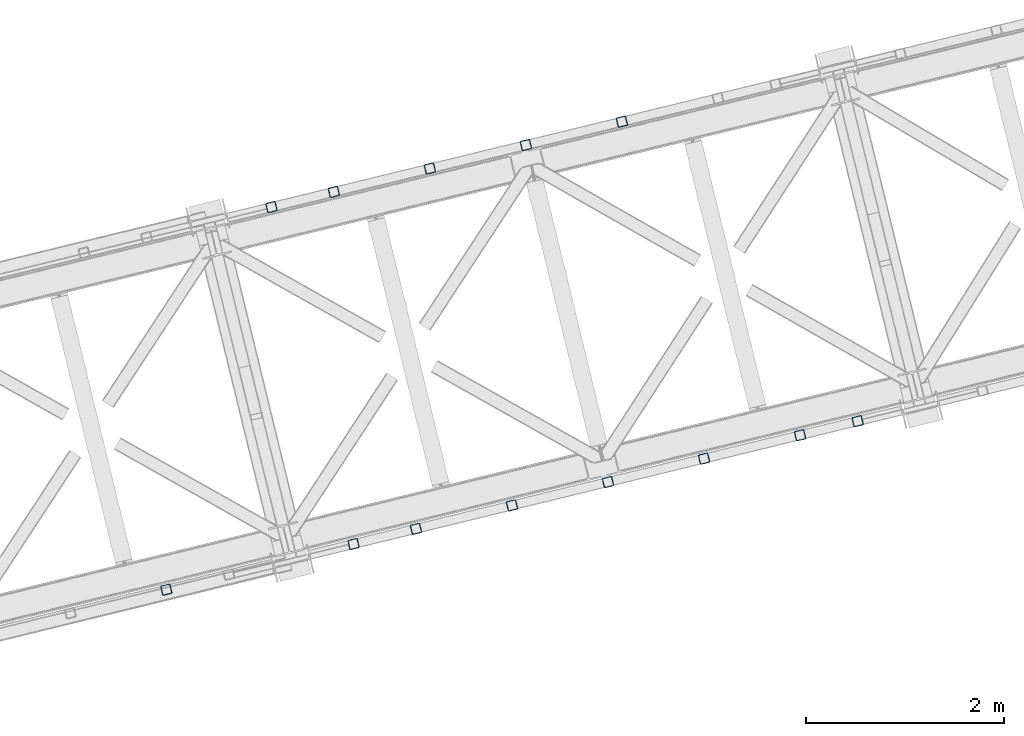
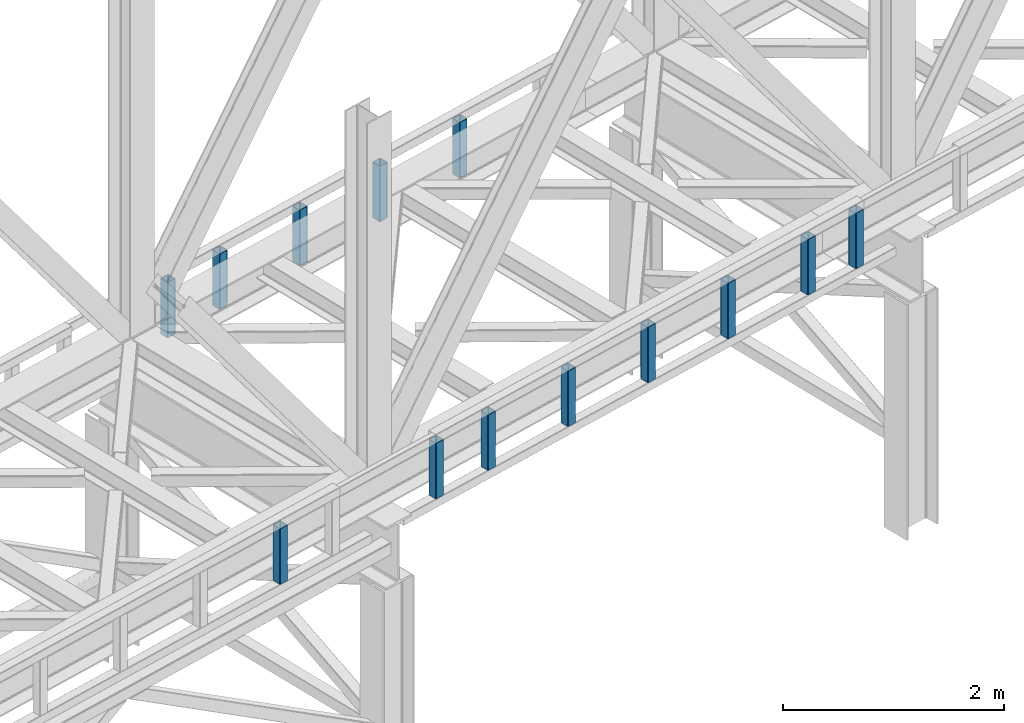
# One storey, part 8 of 93: 13 columns.
"""IFC4 building model written with IfcOpenShell, lengths in millimetres."""

from ifc_helpers import new_model, entity, si_unit, converted_unit, derived_unit, direction, frame, origin, place, context, subcontext, project, spatial, indexed_curve, outline, extrude, type_object, element, save


model = new_model("IFC4")

# Units and contexts
model_context = context("Model", 3, precision=0.01, world=origin(), true_north=direction((6.12303176911189e-17, 1.0)))
plan_context = context("Plan", 3, precision=0.01, world=origin(), true_north=direction((6.12303176911189e-17, 1.0)))
body_context = subcontext(model_context, "Body", "Model", "MODEL_VIEW")
ifc_project = project(units=[si_unit("LENGTHUNIT", "METRE", prefix="MILLI"), si_unit("AREAUNIT", "SQUARE_METRE"), si_unit("VOLUMEUNIT", "CUBIC_METRE"), converted_unit("PLANEANGLEUNIT", "DEGREE", entity("IfcRatioMeasure", 0.0174532925199433), si_unit("PLANEANGLEUNIT", "RADIAN"), dimensions=[0, 0, 0, 0, 0, 0, 0]), si_unit("MASSUNIT", "GRAM", prefix="KILO"), derived_unit("MASSDENSITYUNIT", [(si_unit("MASSUNIT", "GRAM", prefix="KILO"), 1), (si_unit("LENGTHUNIT", "METRE"), -3)]), derived_unit("MOMENTOFINERTIAUNIT", [(si_unit("LENGTHUNIT", "METRE"), 4)]), si_unit("TIMEUNIT", "SECOND"), si_unit("FREQUENCYUNIT", "HERTZ"), si_unit("THERMODYNAMICTEMPERATUREUNIT", "DEGREE_CELSIUS"), derived_unit("THERMALTRANSMITTANCEUNIT", [(si_unit("MASSUNIT", "GRAM", prefix="KILO"), 1), (si_unit("THERMODYNAMICTEMPERATUREUNIT", "KELVIN"), -1), (si_unit("TIMEUNIT", "SECOND"), -3)]), derived_unit("VOLUMETRICFLOWRATEUNIT", [(si_unit("LENGTHUNIT", "METRE"), 3), (si_unit("TIMEUNIT", "SECOND"), -1)]), derived_unit("MASSFLOWRATEUNIT", [(si_unit("MASSUNIT", "GRAM", prefix="KILO"), 1), (si_unit("TIMEUNIT", "SECOND"), -1)]), derived_unit("ROTATIONALFREQUENCYUNIT", [(si_unit("TIMEUNIT", "SECOND"), -1)]), si_unit("ELECTRICCURRENTUNIT", "AMPERE"), si_unit("ELECTRICVOLTAGEUNIT", "VOLT"), si_unit("POWERUNIT", "WATT"), si_unit("FORCEUNIT", "NEWTON", prefix="KILO"), si_unit("ILLUMINANCEUNIT", "LUX"), si_unit("LUMINOUSFLUXUNIT", "LUMEN"), si_unit("LUMINOUSINTENSITYUNIT", "CANDELA"), derived_unit("USERDEFINED", [(si_unit("MASSUNIT", "GRAM", prefix="KILO"), -1), (si_unit("LENGTHUNIT", "METRE"), -2), (si_unit("TIMEUNIT", "SECOND"), 3), (si_unit("LUMINOUSFLUXUNIT", "LUMEN"), 1)]), derived_unit("LINEARVELOCITYUNIT", [(si_unit("LENGTHUNIT", "METRE"), 1), (si_unit("TIMEUNIT", "SECOND"), -1)]), si_unit("PRESSUREUNIT", "PASCAL"), derived_unit("USERDEFINED", [(si_unit("LENGTHUNIT", "METRE"), -2), (si_unit("MASSUNIT", "GRAM", prefix="KILO"), 1), (si_unit("TIMEUNIT", "SECOND"), -2)]), derived_unit("LINEARFORCEUNIT", [(si_unit("MASSUNIT", "GRAM", prefix="KILO"), 1), (si_unit("LENGTHUNIT", "METRE"), 1), (si_unit("TIMEUNIT", "SECOND"), -2), (si_unit("LENGTHUNIT", "METRE"), -1)]), derived_unit("PLANARFORCEUNIT", [(si_unit("MASSUNIT", "GRAM", prefix="KILO"), 1), (si_unit("LENGTHUNIT", "METRE"), 1), (si_unit("TIMEUNIT", "SECOND"), -2), (si_unit("LENGTHUNIT", "METRE"), -2)])], contexts=[model_context, plan_context])

# Site, building, storey
site_placement = place(None, origin())
site = spatial("IfcSite", under=ifc_project, at=site_placement, CompositionType="ELEMENT")
building_placement = place(site_placement, origin())
building = spatial("IfcBuilding", under=site, at=building_placement, CompositionType="ELEMENT")
storey_placement = place(building_placement, frame((0.0, 0.0, 15900.0)))
storey = spatial("IfcBuildingStorey", under=building, at=storey_placement, CompositionType="ELEMENT", Elevation=15900.0)

# Columns
column_type_1 = type_object("IfcColumnType", PredefinedType="COLUMN")
column_1_placement = place(storey_placement, origin())
element("IfcColumn", 1, at=column_1_placement, inside=storey, type_object=column_type_1, ObjectType="Steel Column", PredefinedType="COLUMN", context=body_context, shape_type="SweptSolid", body=[
    extrude(outline(indexed_curve([(29.4768951153002, -56.8428769008257), (33.3787015556201, -56.8428769008257), (36.9835006656566, -55.3497202198225), (39.742494458495, -52.5907264269942), (41.2356511394973, -48.9859273169575), (56.8428769008221, 29.4768951152923), (56.8428769008298, 33.3787015556134), (55.349720219815, 36.9835006656505), (52.5907264269858, 39.7424944584821), (48.9859273169559, 41.2356511394885), (-29.476895115292, 56.8428769008124), (-33.3787015556159, 56.8428769008142), (-36.9835006656493, 55.3497202198072), (-39.7424944584781, 52.5907264269792), (-41.2356511394882, 48.9859273169462), (-56.8428769008091, -29.4768951153055), (-56.8428769008129, -33.3787015556285), (-55.3497202198068, -36.9835006656639), (-52.5907264269816, -39.7424944584937), (-48.9859273169477, -41.2356511395019), (29.4768951153002, -56.8428769008257)], self_intersect=False), holes=[indexed_curve([(-43.1065493048536, -37.3071763475669), (-46.7113484148787, -35.8140196665604), (-49.4703422077127, -33.0550258737289), (-50.9634988887139, -29.4502267636934), (-50.9634988887149, -25.5484203233706), (-37.3071763475512, 43.1065493048462), (-35.8140196665489, 46.7113484148829), (-33.0550258737144, 49.4703422077131), (-29.4502267636828, 50.9634988887161), (-25.5484203233628, 50.9634988887161), (43.1065493048635, 37.3071763475575), (46.7113484148926, 35.8140196665492), (49.4703422077244, 33.0550258737234), (50.9634988887278, 29.4502267636822), (50.9634988887297, 25.5484203233613), (37.307176347576, -43.1065493048649), (35.8140196665589, -46.7113484148923), (33.0550258737274, -49.4703422077263), (29.4502267636918, -50.9634988887275), (25.5484203233728, -50.9634988887255), (-43.1065493048536, -37.3071763475669)], self_intersect=False)]), frame((-32396.3842014728, 13101.2426662819, 3168.0), z_axis=(0.0, 0.0, 1.0), x_axis=(0.906681479027134, 0.421815949898968, 0.0)), (0.0, 0.0, 1.0), 612.000000000008),
])
column_type_2 = type_object("IfcColumnType", PredefinedType="COLUMN")
column_2_placement = place(storey_placement, origin())
element("IfcColumn", 2, at=column_2_placement, inside=storey, type_object=column_type_2, ObjectType="Steel Column", PredefinedType="COLUMN", context=body_context, shape_type="SweptSolid", body=[
    extrude(outline(indexed_curve([(29.4768951153325, -56.8428769008098), (33.3787015556564, -56.8428769008098), (36.9835006656882, -55.3497202198031), (39.7424944585157, -52.5907264269738), (41.2356511395251, -48.9859273169381), (56.8428769008131, 29.476895115319), (56.8428769008112, 33.3787015556438), (55.3497202198034, 36.9835006656785), (52.5907264269769, 39.742494458507), (48.9859273169423, 41.2356511395135), (-29.4768951153177, 56.8428769008006), (-33.3787015556416, 56.8428769008006), (-36.9835006656783, 55.3497202197937), (-39.7424944585018, 52.5907264269625), (-41.2356511395103, 48.9859273169289), (-56.8428769007944, -29.4768951153301), (-56.8428769007964, -33.3787015556531), (-55.3497202197934, -36.9835006656879), (-52.5907264269621, -39.7424944585163), (-48.9859273169275, -41.2356511395228), (29.4768951153325, -56.8428769008098)], self_intersect=False), holes=[indexed_curve([(-43.1065493048312, -37.3071763475869), (-46.711348414861, -35.8140196665803), (-49.4703422076905, -33.055025873748), (-50.9634988886943, -29.4502267637151), (-50.9634988886981, -25.5484203233943), (-37.3071763475696, 43.1065493048327), (-35.8140196665699, 46.7113484148681), (-33.0550258737433, 49.4703422076955), (-29.4502267637009, 50.9634988887044), (-25.5484203233819, 50.9634988887043), (43.1065493048509, 37.3071763475778), (46.7113484148816, 35.8140196665731), (49.470342207712, 33.0550258737428), (50.9634988887197, 29.4502267637081), (50.9634988887226, 25.5484203233853), (37.307176347594, -43.1065493048417), (35.8140196665886, -46.7113484148792), (33.055025873759, -49.4703422077028), (29.4502267637205, -50.9634988887136), (25.5484203233976, -50.9634988887116), (-43.1065493048312, -37.3071763475869)], self_intersect=False)]), frame((-33367.9362596143, 12864.4165732915, 3168.0), z_axis=(0.0, 0.0, 1.0), x_axis=(0.906681479027331, 0.421815949898544, 0.0)), (0.0, 0.0, 1.0), 612.000000000008),
])
column_type_3 = type_object("IfcColumnType", PredefinedType="COLUMN")
column_3_placement = place(storey_placement, origin())
element("IfcColumn", 3, at=column_3_placement, inside=storey, type_object=column_type_3, ObjectType="Steel Column", PredefinedType="COLUMN", context=body_context, shape_type="SweptSolid", body=[
    extrude(outline(indexed_curve([(29.4768951153208, -56.8428769008043), (33.3787015556446, -56.8428769008043), (36.9835006656813, -55.3497202197975), (39.7424944585048, -52.5907264269663), (41.2356511395172, -48.9859273169345), (56.8428769008022, 29.4768951153265), (56.8428769007994, 33.3787015556493), (55.3497202197955, 36.9835006656822), (52.5907264269651, 39.7424944585125), (48.9859273169305, 41.235651139519), (-29.4768951153295, 56.842876900806), (-33.3787015556495, 56.8428769008042), (-36.98350066569, 55.3497202197992), (-39.7424944585175, 52.5907264269698), (-41.235651139522, 48.9859273169343), (-56.8428769008062, -29.4768951153247), (-56.8428769008121, -33.3787015556458), (-55.3497202198052, -36.9835006656825), (-52.5907264269739, -39.7424944585108), (-48.9859273169393, -41.2356511395173), (29.4768951153208, -56.8428769008043)], self_intersect=False), holes=[indexed_curve([(-43.1065493048439, -37.3071763475834), (-46.7113484148737, -35.8140196665768), (-49.4703422077071, -33.0550258737427), (-50.9634988887167, -29.4502267637119), (-50.9634988887148, -25.5484203233889), (-37.3071763475862, 43.106549304838), (-35.8140196665807, 46.7113484148755), (-33.055025873756, 49.470342207699), (-29.4502267637127, 50.9634988887099), (-25.5484203233946, 50.9634988887078), (43.1065493048343, 37.3071763475832), (46.711348414864, 35.8140196665765), (49.4703422076944, 33.0550258737462), (50.963498888707, 29.4502267637116), (50.963498888706, 25.5484203233906), (37.3071763475813, -43.1065493048382), (35.814019666572, -46.7113484148738), (33.0550258737415, -49.4703422076994), (29.4502267637039, -50.9634988887082), (25.5484203233849, -50.9634988887081), (-43.1065493048439, -37.3071763475834)], self_intersect=False)]), frame((-34339.4883177557, 12627.5904803012, 3168.0), z_axis=(0.0, 0.0, 1.0), x_axis=(0.906681479027331, 0.421815949898544, 0.0)), (0.0, 0.0, 1.0), 612.000000000008),
])
column_type_4 = type_object("IfcColumnType", PredefinedType="COLUMN")
column_4_placement = place(storey_placement, origin())
element("IfcColumn", 4, at=column_4_placement, inside=storey, type_object=column_type_4, ObjectType="Steel Column", PredefinedType="COLUMN", context=body_context, shape_type="SweptSolid", body=[
    extrude(outline(indexed_curve([(29.4768951153029, -56.8428769008198), (33.3787015556228, -56.8428769008198), (36.9835006656593, -55.3497202198166), (39.7424944584929, -52.5907264269884), (41.2356511394991, -48.9859273169536), (56.84287690082, 29.4768951152981), (56.8428769008277, 33.3787015556192), (55.3497202198177, 36.9835006656564), (52.5907264269886, 39.742494458488), (48.9859273169586, 41.2356511394944), (-29.4768951152941, 56.8428769008181), (-33.3787015556141, 56.8428769008181), (-36.9835006656514, 55.349720219813), (-39.7424944584841, 52.5907264269867), (-41.2356511394904, 48.9859273169519), (-56.8428769008112, -29.4768951152998), (-56.8428769008189, -33.3787015556209), (-55.3497202198089, -36.9835006656581), (-52.5907264269837, -39.7424944584879), (-48.9859273169498, -41.2356511394961), (29.4768951153029, -56.8428769008198)], self_intersect=False), holes=[indexed_curve([(-43.1065493048517, -37.307176347563), (-46.711348414876, -35.8140196665545), (-49.470342207706, -33.0550258737249), (-50.9634988887111, -29.4502267636875), (-50.9634988887131, -25.5484203233666), (-37.3071763475524, 43.106549304854), (-35.8140196665471, 46.7113484148868), (-33.0550258737126, 49.470342207717), (-29.4502267636801, 50.963498888722), (-25.5484203233601, 50.963498888722), (43.1065493048644, 37.3071763475595), (46.7113484148983, 35.8140196665513), (49.4703422077293, 33.0550258737236), (50.9634988887296, 29.4502267636861), (50.9634988887316, 25.5484203233652), (37.3071763475669, -43.1065493048535), (35.8140196665655, -46.7113484148882), (33.0550258737322, -49.4703422077261), (29.4502267636985, -50.9634988887234), (25.5484203233707, -50.9634988887198), (-43.1065493048517, -37.307176347563)], self_intersect=False)]), frame((-35311.0403758972, 12390.7643873108, 3168.0), z_axis=(0.0, 0.0, 1.0), x_axis=(0.906681479027134, 0.421815949898968, 0.0)), (0.0, 0.0, 1.0), 612.000000000008),
])
column_type_5 = type_object("IfcColumnType", PredefinedType="COLUMN")
column_5_placement = place(storey_placement, origin())
element("IfcColumn", 5, at=column_5_placement, inside=storey, type_object=column_type_5, ObjectType="Steel Column", PredefinedType="COLUMN", context=body_context, shape_type="SweptSolid", body=[
    extrude(outline(indexed_curve([(29.4768951153286, -56.842876900808), (33.3787015556525, -56.842876900808), (36.9835006656843, -55.3497202198013), (39.7424944585166, -52.5907264269718), (41.2356511395211, -48.9859273169363), (56.8428769008092, 29.4768951153209), (56.8428769008112, 33.3787015556438), (55.3497202197995, 36.9835006656803), (52.590726426973, 39.7424944585088), (48.9859273169384, 41.2356511395154), (-29.4768951153217, 56.8428769008024), (-33.3787015556455, 56.8428769008024), (-36.9835006656783, 55.3497202197937), (-39.7424944585097, 52.5907264269662), (-41.2356511395142, 48.9859273169307), (-56.8428769007983, -29.4768951153283), (-56.8428769008042, -33.3787015556494), (-55.3497202197925, -36.983500665686), (-52.590726426966, -39.7424944585145), (-48.9859273169314, -41.235651139521), (29.4768951153286, -56.842876900808)], self_intersect=False), holes=[indexed_curve([(-43.1065493048352, -37.3071763475851), (-46.7113484148659, -35.8140196665804), (-49.4703422076993, -33.0550258737463), (-50.9634988887031, -29.4502267637134), (-50.963498888706, -25.5484203233906), (-37.3071763475783, 43.1065493048344), (-35.8140196665738, 46.7113484148699), (-33.0550258737415, 49.4703422076994), (-29.4502267637048, 50.9634988887063), (-25.5484203233858, 50.9634988887061), (43.106549304843, 37.3071763475815), (46.7113484148719, 35.8140196665728), (49.4703422077062, 33.0550258737407), (50.9634988887149, 29.450226763708), (50.9634988887178, 25.5484203233851), (37.3071763475901, -43.1065493048399), (35.8140196665847, -46.7113484148774), (33.0550258737493, -49.4703422077031), (29.4502267637127, -50.9634988887099), (25.5484203233937, -50.9634988887098), (-43.1065493048352, -37.3071763475851)], self_intersect=False)]), frame((-35942.5492136892, 12236.8274268671, 3168.0), z_axis=(0.0, 0.0, 1.0), x_axis=(0.906681479027331, 0.421815949898544, 0.0)), (0.0, 0.0, 1.0), 612.000000000008),
])
column_type_6 = type_object("IfcColumnType", PredefinedType="COLUMN")
column_6_placement = place(storey_placement, origin())
element("IfcColumn", 6, at=column_6_placement, inside=storey, type_object=column_type_6, ObjectType="Steel Column", PredefinedType="COLUMN", context=body_context, shape_type="SweptSolid", body=[
    extrude(outline(indexed_curve([(29.476895115299, -56.842876900818), (33.3787015556189, -56.842876900818), (36.9835006656514, -55.349720219813), (39.7424944584811, -52.590726426983), (41.2356511394913, -48.98592731695), (56.842876900817, 29.4768951153019), (56.8428769008159, 33.3787015556247), (55.3497202198098, 36.9835006656601), (52.5907264269847, 39.7424944584899), (48.9859273169547, 41.2356511394962), (-29.476895115302, 56.8428769008218), (-33.3787015556259, 56.8428769008236), (-36.9835006656544, 55.3497202198168), (-39.742494458492, 52.5907264269904), (-41.2356511394982, 48.9859273169556), (-56.8428769008191, -29.4768951152961), (-56.8428769008268, -33.3787015556172), (-55.3497202198129, -36.9835006656563), (-52.5907264269916, -39.7424944584843), (-48.9859273169577, -41.2356511394924), (29.476895115299, -56.842876900818)], self_intersect=False), holes=[indexed_curve([(-43.1065493048557, -37.3071763475612), (-46.7113484148896, -35.814019666553), (-49.4703422077205, -33.0550258737253), (-50.9634988887296, -29.4502267636861), (-50.9634988887258, -25.5484203233631), (-37.3071763475739, 43.1065493048592), (-35.814019666554, 46.7113484148924), (-33.0550258737234, 49.4703422077244), (-29.4502267636879, 50.9634988887257), (-25.548420323365, 50.9634988887219), (43.1065493048487, 37.3071763475668), (46.7113484148817, 35.8140196665566), (49.4703422077166, 33.0550258737271), (50.9634988887178, 29.4502267636916), (50.9634988887189, 25.5484203233687), (37.3071763475621, -43.1065493048537), (35.814019666551, -46.7113484148886), (33.0550258737144, -49.4703422077131), (29.450226763681, -50.96349888872), (25.5484203233619, -50.9634988887181), (-43.1065493048557, -37.3071763475612)], self_intersect=False)]), frame((-30010.8781481433, 10070.988243048, 3168.0), z_axis=(0.0, 0.0, 1.0), x_axis=(-0.906681479027134, -0.421815949898968, 0.0)), (0.0, 0.0, 1.0), 612.000000000008),
])
column_type_7 = type_object("IfcColumnType", PredefinedType="COLUMN")
column_7_placement = place(storey_placement, origin())
element("IfcColumn", 7, at=column_7_placement, inside=storey, type_object=column_type_7, ObjectType="Steel Column", PredefinedType="COLUMN", context=body_context, shape_type="SweptSolid", body=[
    extrude(outline(indexed_curve([(29.4768951153029, -56.8428769008198), (33.3787015556228, -56.8428769008198), (36.9835006656554, -55.3497202198148), (39.742494458485, -52.5907264269848), (41.2356511394952, -48.9859273169518), (56.8428769008209, 29.4768951153), (56.8428769008198, 33.3787015556228), (55.3497202198138, 36.9835006656582), (52.5907264269886, 39.742494458488), (48.9859273169586, 41.2356511394944), (-29.4768951152981, 56.84287690082), (-33.3787015556219, 56.8428769008218), (-36.9835006656505, 55.349720219815), (-39.742494458488, 52.5907264269886), (-41.2356511394943, 48.9859273169538), (-56.8428769008151, -29.4768951152979), (-56.8428769008229, -33.3787015556191), (-55.3497202198089, -36.9835006656581), (-52.5907264269877, -39.7424944584861), (-48.9859273169538, -41.2356511394943), (29.4768951153029, -56.8428769008198)], self_intersect=False), holes=[indexed_curve([(-43.1065493048508, -37.307176347561), (-46.7113484148896, -35.814019666553), (-49.4703422077205, -33.0550258737253), (-50.9634988887248, -29.4502267636859), (-50.9634988887258, -25.5484203233631), (-37.307176347569, 43.1065493048593), (-35.814019666554, 46.7113484148924), (-33.0550258737234, 49.4703422077244), (-29.4502267636831, 50.9634988887258), (-25.5484203233601, 50.963498888722), (43.1065493048536, 37.3071763475669), (46.7113484148856, 35.8140196665548), (49.4703422077166, 33.0550258737271), (50.9634988887178, 29.4502267636916), (50.9634988887189, 25.5484203233687), (37.307176347563, -43.1065493048517), (35.814019666551, -46.7113484148886), (33.0550258737192, -49.4703422077129), (29.4502267636858, -50.9634988887199), (25.5484203233668, -50.9634988887179), (-43.1065493048508, -37.307176347561)], self_intersect=False)]), frame((-30593.8093830282, 9928.89258725376, 3168.0), z_axis=(0.0, 0.0, 1.0), x_axis=(-0.906681479027134, -0.421815949898968, 0.0)), (0.0, 0.0, 1.0), 612.000000000008),
])
column_type_8 = type_object("IfcColumnType", PredefinedType="COLUMN")
column_8_placement = place(storey_placement, origin())
element("IfcColumn", 8, at=column_8_placement, inside=storey, type_object=column_type_8, ObjectType="Steel Column", PredefinedType="COLUMN", context=body_context, shape_type="SweptSolid", body=[
    extrude(outline(indexed_curve([(29.4768951153128, -56.8428769008116), (33.3787015556323, -56.8428769008116), (36.9835006656693, -55.3497202198055), (39.7424944584973, -52.5907264269767), (41.2356511395066, -48.9859273169434), (56.8428769008086, 29.4768951153142), (56.842876900811, 33.3787015556362), (55.349720219804, 36.9835006656712), (52.5907264269781, 39.7424944585003), (48.9859273169438, 41.2356511395076), (-29.4768951153084, 56.8428769008107), (-33.3787015556279, 56.8428769008107), (-36.9835006656644, 55.3497202198056), (-39.7424944585017, 52.5907264269776), (-41.2356511395066, 48.9859273169434), (-56.8428769008082, -29.4768951153132), (-56.8428769008149, -33.3787015556344), (-55.3497202197996, -36.983500665672), (-52.5907264269733, -39.7424944585002), (-48.9859273169395, -41.2356511395084), (29.4768951153128, -56.8428769008116)], self_intersect=False), holes=[indexed_curve([(-43.1065493048467, -37.307176347573), (-46.711348414881, -35.8140196665657), (-49.4703422077087, -33.0550258737405), (-50.9634988887134, -29.4502267637006), (-50.9634988887159, -25.5484203233788), (-37.3071763475803, 43.1065493048489), (-35.8140196665637, 46.7113484148777), (-33.0550258737329, 49.4703422077123), (-29.4502267637021, 50.9634988887153), (-25.5484203233782, 50.9634988887145), (43.1065493048467, 37.307176347573), (46.7113484148792, 35.8140196665618), (49.4703422077113, 33.0550258737358), (50.9634988887134, 29.4502267637006), (50.963498888715, 25.5484203233768), (37.307176347569, -43.1065493048425), (35.8140196665676, -46.7113484148795), (33.0550258737294, -49.4703422077095), (29.4502267637026, -50.9634988887143), (25.5484203233826, -50.9634988887153), (-43.1065493048467, -37.307176347573)], self_intersect=False)]), frame((-31565.3614411697, 9692.06649426342, 3168.0), z_axis=(0.0, 0.0, 1.0), x_axis=(-0.90668147902724, -0.42181594989874, 0.0)), (0.0, 0.0, 1.0), 612.000000000008),
])
column_type_9 = type_object("IfcColumnType", PredefinedType="COLUMN")
column_9_placement = place(storey_placement, origin())
element("IfcColumn", 9, at=column_9_placement, inside=storey, type_object=column_type_9, ObjectType="Steel Column", PredefinedType="COLUMN", context=body_context, shape_type="SweptSolid", body=[
    extrude(outline(indexed_curve([(29.4768951153119, -56.8428769008135), (33.3787015556314, -56.8428769008135), (36.9835006656728, -55.3497202198083), (39.7424944584964, -52.5907264269787), (41.2356511395061, -48.9859273169443), (56.8428769008077, 29.4768951153122), (56.8428769008101, 33.3787015556342), (55.3497202198075, 36.9835006656684), (52.5907264269772, 39.7424944584983), (48.9859273169429, 41.2356511395056), (-29.4768951153133, 56.8428769008106), (-33.3787015556376, 56.8428769008104), (-36.9835006656697, 55.3497202198045), (-39.7424944584983, 52.5907264269748), (-41.2356511395119, 48.9859273169422), (-56.8428769008135, -29.4768951153144), (-56.8428769008114, -33.3787015556372), (-55.3497202198049, -36.9835006656732), (-52.590726426979, -39.7424944585023), (-48.9859273169443, -41.2356511395086), (29.4768951153119, -56.8428769008135)], self_intersect=False), holes=[indexed_curve([(-43.1065493048476, -37.307176347575), (-46.7113484148863, -35.8140196665668), (-49.4703422077122, -33.0550258737377), (-50.9634988887192, -29.4502267637027), (-50.9634988887207, -25.5484203233789), (-37.3071763475778, 43.1065493048442), (-35.814019666572, 46.7113484148803), (-33.0550258737404, 49.4703422077063), (-29.4502267637069, 50.9634988887152), (-25.5484203233791, 50.9634988887125), (43.1065493048419, 37.3071763475729), (46.7113484148752, 35.8140196665636), (49.4703422077046, 33.0550258737317), (50.9634988887077, 29.4502267636985), (50.9634988887101, 25.5484203233767), (37.3071763475672, -43.1065493048464), (35.8140196665667, -46.7113484148814), (33.0550258737356, -49.4703422077064), (29.4502267636973, -50.9634988887154), (25.5484203233773, -50.9634988887164), (-43.1065493048476, -37.307176347575)], self_intersect=False)]), frame((-32536.9134993112, 9455.24040127308, 3168.0), z_axis=(0.0, 0.0, 1.0), x_axis=(-0.90668147902724, -0.42181594989874, 0.0)), (0.0, 0.0, 1.0), 612.000000000008),
])
column_type_10 = type_object("IfcColumnType", PredefinedType="COLUMN")
column_10_placement = place(storey_placement, origin())
element("IfcColumn", 10, at=column_10_placement, inside=storey, type_object=column_type_10, ObjectType="Steel Column", PredefinedType="COLUMN", context=body_context, shape_type="SweptSolid", body=[
    extrude(outline(indexed_curve([(29.4768951153089, -56.8428769008097), (33.3787015556284, -56.8428769008097), (36.9835006656693, -55.3497202198055), (39.7424944584978, -52.5907264269757), (41.2356511395027, -48.9859273169415), (56.8428769008042, 29.4768951153151), (56.842876900811, 33.3787015556362), (55.3497202198045, 36.9835006656722), (52.5907264269698, 39.742494458503), (48.9859273169399, 41.2356511395094), (-29.4768951153167, 56.8428769008134), (-33.3787015556406, 56.8428769008142), (-36.9835006656771, 55.3497202198091), (-39.7424944585013, 52.5907264269785), (-41.2356511395149, 48.985927316946), (-56.8428769008165, -29.4768951153106), (-56.8428769008149, -33.3787015556344), (-55.3497202198123, -36.9835006656685), (-52.590726426986, -39.7424944584967), (-48.9859273169478, -41.2356511395058), (29.4768951153089, -56.8428769008097)], self_intersect=False), holes=[indexed_curve([(-43.1065493048506, -37.3071763475712), (-46.7113484148849, -35.8140196665639), (-49.4703422077113, -33.0550258737358), (-50.9634988887222, -29.4502267636989), (-50.9634988887198, -25.548420323377), (-37.3071763475808, 43.1065493048479), (-35.8140196665711, 46.7113484148823), (-33.0550258737395, 49.4703422077082), (-29.450226763706, 50.9634988887171), (-25.5484203233822, 50.9634988887163), (43.1065493048379, 37.3071763475747), (46.7113484148727, 35.8140196665684), (49.4703422077055, 33.0550258737337), (50.9634988887143, 29.4502267637026), (50.9634988887111, 25.5484203233787), (37.3071763475681, -43.1065493048444), (35.8140196665623, -46.7113484148806), (33.0550258737326, -49.4703422077026), (29.4502267636933, -50.9634988887136), (25.5484203233743, -50.9634988887126), (-43.1065493048506, -37.3071763475712)], self_intersect=False)]), frame((-33508.4655574526, 9218.41430828275, 3168.0), z_axis=(0.0, 0.0, 1.0), x_axis=(-0.90668147902724, -0.42181594989874, 0.0)), (0.0, 0.0, 1.0), 612.000000000008),
])
column_type_11 = type_object("IfcColumnType", PredefinedType="COLUMN")
column_11_placement = place(storey_placement, origin())
element("IfcColumn", 11, at=column_11_placement, inside=storey, type_object=column_type_11, ObjectType="Steel Column", PredefinedType="COLUMN", context=body_context, shape_type="SweptSolid", body=[
    extrude(outline(indexed_curve([(29.4768951153128, -56.8428769008116), (33.3787015556323, -56.8428769008116), (36.9835006656693, -55.3497202198055), (39.7424944585017, -52.5907264269776), (41.2356511395066, -48.9859273169434), (56.8428769008086, 29.4768951153142), (56.8428769008149, 33.3787015556344), (55.349720219804, 36.9835006656712), (52.5907264269737, 39.7424944585011), (48.9859273169438, 41.2356511395076), (-29.4768951153128, 56.8428769008116), (-33.3787015556323, 56.8428769008116), (-36.9835006656688, 55.3497202198065), (-39.7424944585017, 52.5907264269776), (-41.2356511395066, 48.9859273169434), (-56.8428769008082, -29.4768951153132), (-56.8428769008149, -33.3787015556344), (-55.349720219804, -36.9835006656712), (-52.5907264269776, -39.7424944584993), (-48.9859273169438, -41.2356511395076), (29.4768951153128, -56.8428769008116)], self_intersect=False), holes=[indexed_curve([(-43.1065493048467, -37.307176347573), (-46.7113484148884, -35.8140196665611), (-49.4703422077161, -33.0550258737359), (-50.9634988887173, -29.4502267636988), (-50.9634988887194, -25.548420323376), (-37.3071763475729, 43.1065493048443), (-35.814019666572, 46.7113484148803), (-33.0550258737403, 49.470342207717), (-29.45022676371, 50.963498888719), (-25.5484203233778, 50.9634988887154), (43.1065493048423, 37.3071763475738), (46.7113484148757, 35.8140196665646), (49.470342207703, 33.0550258737384), (50.9634988887095, 29.4502267637024), (50.9634988887115, 25.5484203233796), (37.3071763475685, -43.1065493048435), (35.8140196665641, -46.7113484148767), (33.0550258737259, -49.4703422077067), (29.4502267636982, -50.9634988887135), (25.5484203233782, -50.9634988887145), (-43.1065493048467, -37.307176347573)], self_intersect=False)]), frame((-34480.0176155941, 8981.58821529241, 3168.0), z_axis=(0.0, 0.0, 1.0), x_axis=(-0.90668147902724, -0.42181594989874, 0.0)), (0.0, 0.0, 1.0), 612.000000000008),
])
column_type_12 = type_object("IfcColumnType", PredefinedType="COLUMN")
column_12_placement = place(storey_placement, origin())
element("IfcColumn", 12, at=column_12_placement, inside=storey, type_object=column_type_12, ObjectType="Steel Column", PredefinedType="COLUMN", context=body_context, shape_type="SweptSolid", body=[
    extrude(outline(indexed_curve([(29.476895115305, -56.8428769008079), (33.3787015556245, -56.8428769008079), (36.9835006656614, -55.3497202198019), (39.7424944584939, -52.5907264269739), (41.2356511394987, -48.9859273169397), (56.8428769008008, 29.4768951153179), (56.8428769008075, 33.378701555639), (55.3497202197961, 36.9835006656748), (52.5907264269703, 39.7424944585039), (48.985927316936, 41.2356511395112), (-29.4768951153207, 56.8428769008152), (-33.3787015556446, 56.8428769008161), (-36.9835006656767, 55.3497202198101), (-39.7424944585096, 52.5907264269812), (-41.2356511395188, 48.9859273169479), (-56.8428769008204, -29.4768951153087), (-56.8428769008228, -33.3787015556307), (-55.3497202198119, -36.9835006656675), (-52.590726426986, -39.7424944584966), (-48.9859273169512, -41.2356511395029), (29.476895115305, -56.8428769008079)], self_intersect=False), holes=[indexed_curve([(-43.1065493048546, -37.3071763475693), (-46.7113484148879, -35.8140196665601), (-49.4703422077182, -33.0550258737301), (-50.9634988887256, -29.4502267636961), (-50.9634988887268, -25.5484203233713), (-37.3071763475847, 43.1065493048498), (-35.8140196665789, 46.711348414886), (-33.0550258737421, 49.470342207713), (-29.45022676371, 50.963498888719), (-25.5484203233861, 50.9634988887181), (43.1065493048349, 37.3071763475785), (46.7113484148697, 35.8140196665722), (49.470342207702, 33.0550258737365), (50.963498888706, 29.4502267637052), (50.9634988887071, 25.5484203233805), (37.3071763475651, -43.1065493048406), (35.8140196665606, -46.7113484148739), (33.0550258737225, -49.4703422077039), (29.4502267636903, -50.9634988887098), (25.5484203233704, -50.9634988887108), (-43.1065493048546, -37.3071763475693)], self_intersect=False)]), frame((-35111.5264533861, 8827.65125484869, 3168.0), z_axis=(0.0, 0.0, 1.0), x_axis=(-0.90668147902724, -0.42181594989874, 0.0)), (0.0, 0.0, 1.0), 612.000000000008),
])
column_type_13 = type_object("IfcColumnType", PredefinedType="COLUMN")
column_13_placement = place(storey_placement, origin())
element("IfcColumn", 13, at=column_13_placement, inside=storey, type_object=column_type_13, ObjectType="Steel Column", PredefinedType="COLUMN", context=body_context, shape_type="SweptSolid", body=[
    extrude(outline(indexed_curve([(29.4768951153133, -56.8428769008106), (33.3787015556328, -56.8428769008106), (36.9835006656737, -55.3497202198063), (39.7424944584978, -52.5907264269757), (41.235651139507, -48.9859273169424), (56.8428769008086, 29.4768951153142), (56.842876900811, 33.3787015556362), (55.3497202198088, 36.9835006656714), (52.5907264269742, 39.7424944585022), (48.9859273169443, 41.2356511395086), (-29.4768951153124, 56.8428769008125), (-33.3787015556319, 56.8428769008125), (-36.9835006656688, 55.3497202198065), (-39.7424944584969, 52.5907264269777), (-41.2356511395105, 48.9859273169452), (-56.8428769008121, -29.4768951153114), (-56.8428769008105, -33.3787015556352), (-55.3497202198035, -36.9835006656702), (-52.5907264269776, -39.7424944584993), (-48.9859273169434, -41.2356511395066), (29.4768951153133, -56.8428769008106)], self_intersect=False), holes=[indexed_curve([(-43.1065493048463, -37.307176347572), (-46.7113484148805, -35.8140196665647), (-49.4703422077055, -33.0550258737337), (-50.9634988887139, -29.4502267637016), (-50.9634988887154, -25.5484203233778), (-37.3071763475729, 43.1065493048443), (-35.8140196665628, 46.7113484148796), (-33.0550258737351, 49.4703422077074), (-29.4502267637017, 50.9634988887163), (-25.5484203233778, 50.9634988887154), (43.1065493048432, 37.3071763475758), (46.7113484148766, 35.8140196665666), (49.4703422077099, 33.0550258737328), (50.9634988887139, 29.4502267637016), (50.9634988887154, 25.5484203233778), (37.3071763475725, -43.1065493048453), (35.8140196665667, -46.7113484148814), (33.055025873737, -49.4703422077035), (29.4502267636986, -50.9634988887125), (25.5484203233787, -50.9634988887135), (-43.1065493048463, -37.307176347572)], self_intersect=False)]), frame((-37006.0529667619, 8365.84037351754, 3168.0), z_axis=(0.0, 0.0, 1.0), x_axis=(-0.90668147902724, -0.42181594989874, 0.0)), (0.0, 0.0, 1.0), 612.000000000008),
])

save(model, "model.ifc")
